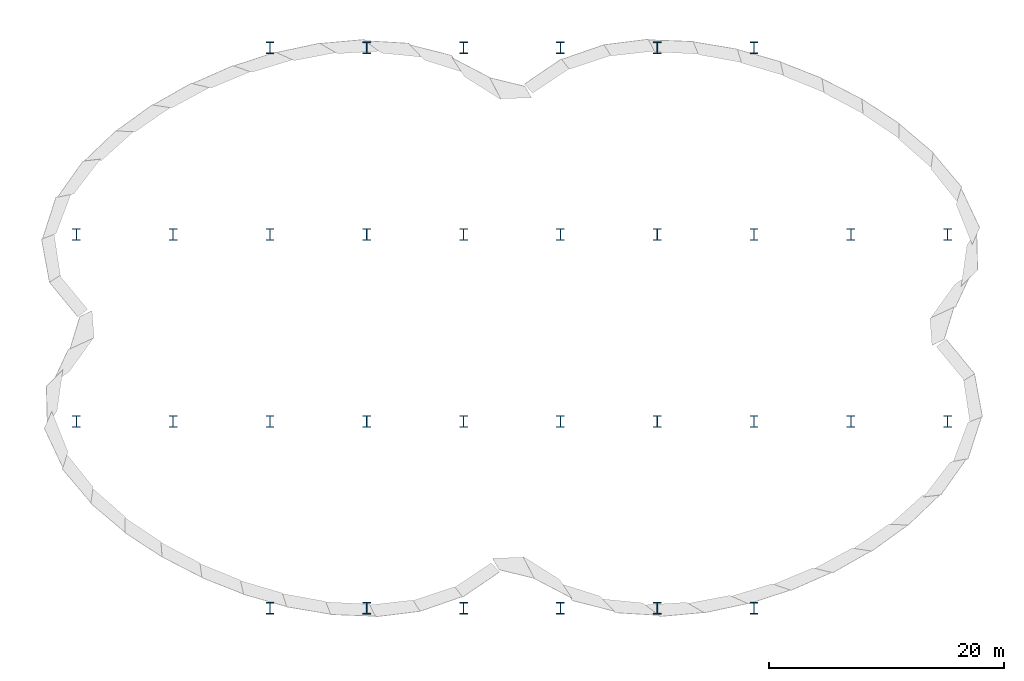
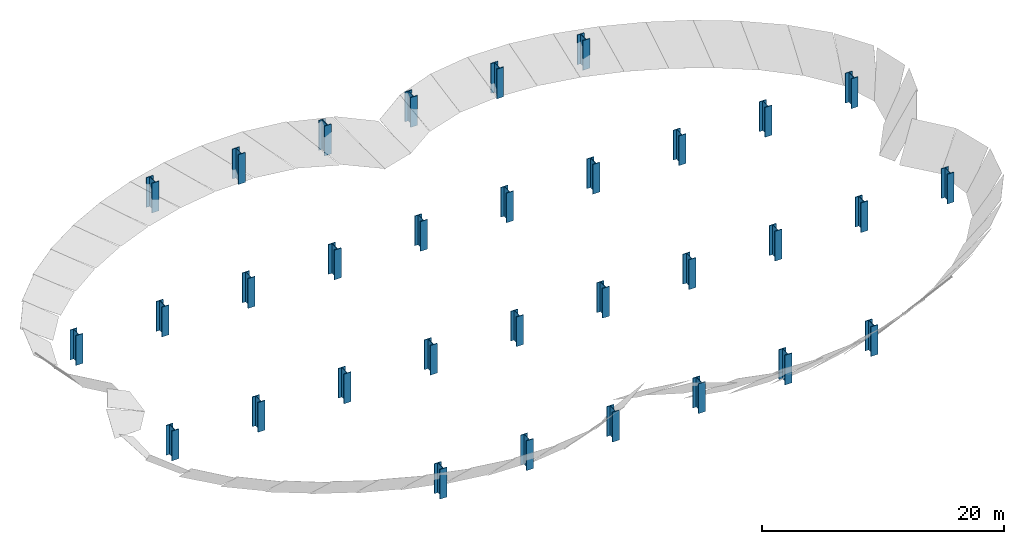
# One storey, part 1 of 2: 32 columns.
"""IFC2X3 building model written with IfcOpenShell, lengths in metres."""

from ifc_helpers import new_model, si_unit, direction, origin_with_axes, place, context, project, spatial, polyline, outline, extrude, source, transform, mapped, element, save


model = new_model("IFC2X3")

# Units and contexts
model_context = context("Model", 3, precision=1e-05, world=origin_with_axes(), true_north=direction((0.0, 1.0, 0.0)), identifier="Body")
ifc_project = project(units=[si_unit("LENGTHUNIT", "METRE"), si_unit("AREAUNIT", "SQUARE_METRE"), si_unit("VOLUMEUNIT", "CUBIC_METRE"), si_unit("PLANEANGLEUNIT", "RADIAN")], contexts=[model_context])

# Site, building, storey
site_placement = place(None, origin_with_axes())
site = spatial("IfcSite", under=ifc_project, at=site_placement, CompositionType="ELEMENT")
building_placement = place(None, origin_with_axes())
building = spatial("IfcBuilding", under=site, at=building_placement, Name="GH DEMO", CompositionType="ELEMENT")
storey_placement = place(None, origin_with_axes())
storey = spatial("IfcBuildingStorey", under=building, at=storey_placement, Name="Ground", CompositionType="ELEMENT")

# Columns
shared_shape_1 = source(origin_with_axes(), model_context, "Body", "SweptSolid", [
    extrude(outline(polyline([(0.025, -0.433333333333333), (0.025, 0.433333333333333), (0.333333333333333, 0.433333333333333), (0.333333333333333, 0.5), (-0.333333333333333, 0.5), (-0.333333333333333, 0.433333333333333), (-0.025, 0.433333333333333), (-0.025, -0.433333333333333), (-0.333333333333333, -0.433333333333333), (-0.333333333333333, -0.5), (0.333333333333333, -0.5), (0.333333333333333, -0.433333333333333), (0.025, -0.433333333333333)])), origin_with_axes(), (0.0, 0.0, 1.0), 3.0),
])
column_1_placement = place(None, origin_with_axes())
element("IfcColumn", 1, at=column_1_placement, inside=storey, context=model_context, shape_type="MappedRepresentation", body=[
    mapped(shared_shape_1, transform((4.1125, -7.9375, 0.0), x_axis=(1.0, 0.0, 0.0), y_axis=(0.0, 1.0, 0.0), z_axis=(0.0, 0.0, 1.0), scale=1.0)),
])
shared_shape_2 = source(origin_with_axes(), model_context, "Body", "SweptSolid", [
    extrude(outline(polyline([(0.025, -0.433333333333333), (0.025, 0.433333333333333), (0.333333333333333, 0.433333333333333), (0.333333333333333, 0.5), (-0.333333333333333, 0.5), (-0.333333333333333, 0.433333333333333), (-0.025, 0.433333333333333), (-0.025, -0.433333333333333), (-0.333333333333333, -0.433333333333333), (-0.333333333333333, -0.5), (0.333333333333333, -0.5), (0.333333333333333, -0.433333333333333), (0.025, -0.433333333333333)])), origin_with_axes(), (0.0, 0.0, 1.0), 3.0),
])
column_2_placement = place(None, origin_with_axes())
element("IfcColumn", 2, at=column_2_placement, inside=storey, context=model_context, shape_type="MappedRepresentation", body=[
    mapped(shared_shape_2, transform((12.3375, -7.9375, 0.0), x_axis=(1.0, 0.0, 0.0), y_axis=(0.0, 1.0, 0.0), z_axis=(0.0, 0.0, 1.0), scale=1.0)),
])
shared_shape_3 = source(origin_with_axes(), model_context, "Body", "SweptSolid", [
    extrude(outline(polyline([(0.025, -0.433333333333333), (0.025, 0.433333333333333), (0.333333333333333, 0.433333333333333), (0.333333333333333, 0.5), (-0.333333333333333, 0.5), (-0.333333333333333, 0.433333333333333), (-0.025, 0.433333333333333), (-0.025, -0.433333333333333), (-0.333333333333333, -0.433333333333333), (-0.333333333333333, -0.5), (0.333333333333333, -0.5), (0.333333333333333, -0.433333333333333), (0.025, -0.433333333333333)])), origin_with_axes(), (0.0, 0.0, 1.0), 3.0),
])
column_3_placement = place(None, origin_with_axes())
element("IfcColumn", 3, at=column_3_placement, inside=storey, context=model_context, shape_type="MappedRepresentation", body=[
    mapped(shared_shape_3, transform((20.5625, -7.9375, 0.0), x_axis=(1.0, 0.0, 0.0), y_axis=(0.0, 1.0, 0.0), z_axis=(0.0, 0.0, 1.0), scale=1.0)),
])
shared_shape_4 = source(origin_with_axes(), model_context, "Body", "SweptSolid", [
    extrude(outline(polyline([(0.025, -0.433333333333333), (0.025, 0.433333333333333), (0.333333333333333, 0.433333333333333), (0.333333333333333, 0.5), (-0.333333333333333, 0.5), (-0.333333333333333, 0.433333333333333), (-0.025, 0.433333333333333), (-0.025, -0.433333333333333), (-0.333333333333333, -0.433333333333333), (-0.333333333333333, -0.5), (0.333333333333333, -0.5), (0.333333333333333, -0.433333333333333), (0.025, -0.433333333333333)])), origin_with_axes(), (0.0, 0.0, 1.0), 3.0),
])
column_4_placement = place(None, origin_with_axes())
element("IfcColumn", 4, at=column_4_placement, inside=storey, context=model_context, shape_type="MappedRepresentation", body=[
    mapped(shared_shape_4, transform((28.7875, -7.9375, 0.0), x_axis=(1.0, 0.0, 0.0), y_axis=(0.0, 1.0, 0.0), z_axis=(0.0, 0.0, 1.0), scale=1.0)),
])
shared_shape_5 = source(origin_with_axes(), model_context, "Body", "SweptSolid", [
    extrude(outline(polyline([(0.025, -0.433333333333333), (0.025, 0.433333333333333), (0.333333333333333, 0.433333333333333), (0.333333333333333, 0.5), (-0.333333333333333, 0.5), (-0.333333333333333, 0.433333333333333), (-0.025, 0.433333333333333), (-0.025, -0.433333333333333), (-0.333333333333333, -0.433333333333333), (-0.333333333333333, -0.5), (0.333333333333333, -0.5), (0.333333333333333, -0.433333333333333), (0.025, -0.433333333333333)])), origin_with_axes(), (0.0, 0.0, 1.0), 3.0),
])
column_5_placement = place(None, origin_with_axes())
element("IfcColumn", 5, at=column_5_placement, inside=storey, context=model_context, shape_type="MappedRepresentation", body=[
    mapped(shared_shape_5, transform((37.0125, -7.9375, 0.0), x_axis=(1.0, 0.0, 0.0), y_axis=(0.0, 1.0, 0.0), z_axis=(0.0, 0.0, 1.0), scale=1.0)),
])
shared_shape_6 = source(origin_with_axes(), model_context, "Body", "SweptSolid", [
    extrude(outline(polyline([(0.025, -0.433333333333333), (0.025, 0.433333333333333), (0.333333333333333, 0.433333333333333), (0.333333333333333, 0.5), (-0.333333333333333, 0.5), (-0.333333333333333, 0.433333333333333), (-0.025, 0.433333333333333), (-0.025, -0.433333333333333), (-0.333333333333333, -0.433333333333333), (-0.333333333333333, -0.5), (0.333333333333333, -0.5), (0.333333333333333, -0.433333333333333), (0.025, -0.433333333333333)])), origin_with_axes(), (0.0, 0.0, 1.0), 3.0),
])
column_6_placement = place(None, origin_with_axes())
element("IfcColumn", 6, at=column_6_placement, inside=storey, context=model_context, shape_type="MappedRepresentation", body=[
    mapped(shared_shape_6, transform((-4.1125, -7.9375, 0.0), x_axis=(1.0, 0.0, 0.0), y_axis=(0.0, 1.0, 0.0), z_axis=(0.0, 0.0, 1.0), scale=1.0)),
])
shared_shape_7 = source(origin_with_axes(), model_context, "Body", "SweptSolid", [
    extrude(outline(polyline([(0.025, -0.433333333333333), (0.025, 0.433333333333333), (0.333333333333333, 0.433333333333333), (0.333333333333333, 0.5), (-0.333333333333333, 0.5), (-0.333333333333333, 0.433333333333333), (-0.025, 0.433333333333333), (-0.025, -0.433333333333333), (-0.333333333333333, -0.433333333333333), (-0.333333333333333, -0.5), (0.333333333333333, -0.5), (0.333333333333333, -0.433333333333333), (0.025, -0.433333333333333)])), origin_with_axes(), (0.0, 0.0, 1.0), 3.0),
])
column_7_placement = place(None, origin_with_axes())
element("IfcColumn", 7, at=column_7_placement, inside=storey, context=model_context, shape_type="MappedRepresentation", body=[
    mapped(shared_shape_7, transform((-12.3375, -7.9375, 0.0), x_axis=(1.0, 0.0, 0.0), y_axis=(0.0, 1.0, 0.0), z_axis=(0.0, 0.0, 1.0), scale=1.0)),
])
shared_shape_8 = source(origin_with_axes(), model_context, "Body", "SweptSolid", [
    extrude(outline(polyline([(0.025, -0.433333333333333), (0.025, 0.433333333333333), (0.333333333333333, 0.433333333333333), (0.333333333333333, 0.5), (-0.333333333333333, 0.5), (-0.333333333333333, 0.433333333333333), (-0.025, 0.433333333333333), (-0.025, -0.433333333333333), (-0.333333333333333, -0.433333333333333), (-0.333333333333333, -0.5), (0.333333333333333, -0.5), (0.333333333333333, -0.433333333333333), (0.025, -0.433333333333333)])), origin_with_axes(), (0.0, 0.0, 1.0), 3.0),
])
column_8_placement = place(None, origin_with_axes())
element("IfcColumn", 8, at=column_8_placement, inside=storey, context=model_context, shape_type="MappedRepresentation", body=[
    mapped(shared_shape_8, transform((-20.5625, -7.9375, 0.0), x_axis=(1.0, 0.0, 0.0), y_axis=(0.0, 1.0, 0.0), z_axis=(0.0, 0.0, 1.0), scale=1.0)),
])
shared_shape_9 = source(origin_with_axes(), model_context, "Body", "SweptSolid", [
    extrude(outline(polyline([(0.025, -0.433333333333333), (0.025, 0.433333333333333), (0.333333333333333, 0.433333333333333), (0.333333333333333, 0.5), (-0.333333333333333, 0.5), (-0.333333333333333, 0.433333333333333), (-0.025, 0.433333333333333), (-0.025, -0.433333333333333), (-0.333333333333333, -0.433333333333333), (-0.333333333333333, -0.5), (0.333333333333333, -0.5), (0.333333333333333, -0.433333333333333), (0.025, -0.433333333333333)])), origin_with_axes(), (0.0, 0.0, 1.0), 3.0),
])
column_9_placement = place(None, origin_with_axes())
element("IfcColumn", 9, at=column_9_placement, inside=storey, context=model_context, shape_type="MappedRepresentation", body=[
    mapped(shared_shape_9, transform((-28.7875, -7.9375, 0.0), x_axis=(1.0, 0.0, 0.0), y_axis=(0.0, 1.0, 0.0), z_axis=(0.0, 0.0, 1.0), scale=1.0)),
])
shared_shape_10 = source(origin_with_axes(), model_context, "Body", "SweptSolid", [
    extrude(outline(polyline([(0.025, -0.433333333333333), (0.025, 0.433333333333333), (0.333333333333333, 0.433333333333333), (0.333333333333333, 0.5), (-0.333333333333333, 0.5), (-0.333333333333333, 0.433333333333333), (-0.025, 0.433333333333333), (-0.025, -0.433333333333333), (-0.333333333333333, -0.433333333333333), (-0.333333333333333, -0.5), (0.333333333333333, -0.5), (0.333333333333333, -0.433333333333333), (0.025, -0.433333333333333)])), origin_with_axes(), (0.0, 0.0, 1.0), 3.0),
])
column_10_placement = place(None, origin_with_axes())
element("IfcColumn", 10, at=column_10_placement, inside=storey, context=model_context, shape_type="MappedRepresentation", body=[
    mapped(shared_shape_10, transform((-37.0125, -7.9375, 0.0), x_axis=(1.0, 0.0, 0.0), y_axis=(0.0, 1.0, 0.0), z_axis=(0.0, 0.0, 1.0), scale=1.0)),
])
shared_shape_11 = source(origin_with_axes(), model_context, "Body", "SweptSolid", [
    extrude(outline(polyline([(0.025, -0.433333333333333), (0.025, 0.433333333333333), (0.333333333333333, 0.433333333333333), (0.333333333333333, 0.5), (-0.333333333333333, 0.5), (-0.333333333333333, 0.433333333333333), (-0.025, 0.433333333333333), (-0.025, -0.433333333333333), (-0.333333333333333, -0.433333333333333), (-0.333333333333333, -0.5), (0.333333333333333, -0.5), (0.333333333333333, -0.433333333333333), (0.025, -0.433333333333333)])), origin_with_axes(), (0.0, 0.0, 1.0), 3.0),
])
column_11_placement = place(None, origin_with_axes())
element("IfcColumn", 11, at=column_11_placement, inside=storey, context=model_context, shape_type="MappedRepresentation", body=[
    mapped(shared_shape_11, transform((4.1125, -23.8125, 0.0), x_axis=(1.0, 0.0, 0.0), y_axis=(0.0, 1.0, 0.0), z_axis=(0.0, 0.0, 1.0), scale=1.0)),
])
shared_shape_12 = source(origin_with_axes(), model_context, "Body", "SweptSolid", [
    extrude(outline(polyline([(0.025, -0.433333333333333), (0.025, 0.433333333333333), (0.333333333333333, 0.433333333333333), (0.333333333333333, 0.5), (-0.333333333333333, 0.5), (-0.333333333333333, 0.433333333333333), (-0.025, 0.433333333333333), (-0.025, -0.433333333333333), (-0.333333333333333, -0.433333333333333), (-0.333333333333333, -0.5), (0.333333333333333, -0.5), (0.333333333333333, -0.433333333333333), (0.025, -0.433333333333333)])), origin_with_axes(), (0.0, 0.0, 1.0), 3.0),
])
column_12_placement = place(None, origin_with_axes())
element("IfcColumn", 12, at=column_12_placement, inside=storey, context=model_context, shape_type="MappedRepresentation", body=[
    mapped(shared_shape_12, transform((12.3375, -23.8125, 0.0), x_axis=(1.0, 0.0, 0.0), y_axis=(0.0, 1.0, 0.0), z_axis=(0.0, 0.0, 1.0), scale=1.0)),
])
shared_shape_13 = source(origin_with_axes(), model_context, "Body", "SweptSolid", [
    extrude(outline(polyline([(0.025, -0.433333333333333), (0.025, 0.433333333333333), (0.333333333333333, 0.433333333333333), (0.333333333333333, 0.5), (-0.333333333333333, 0.5), (-0.333333333333333, 0.433333333333333), (-0.025, 0.433333333333333), (-0.025, -0.433333333333333), (-0.333333333333333, -0.433333333333333), (-0.333333333333333, -0.5), (0.333333333333333, -0.5), (0.333333333333333, -0.433333333333333), (0.025, -0.433333333333333)])), origin_with_axes(), (0.0, 0.0, 1.0), 3.0),
])
column_13_placement = place(None, origin_with_axes())
element("IfcColumn", 13, at=column_13_placement, inside=storey, context=model_context, shape_type="MappedRepresentation", body=[
    mapped(shared_shape_13, transform((20.5625, -23.8125, 0.0), x_axis=(1.0, 0.0, 0.0), y_axis=(0.0, 1.0, 0.0), z_axis=(0.0, 0.0, 1.0), scale=1.0)),
])
shared_shape_14 = source(origin_with_axes(), model_context, "Body", "SweptSolid", [
    extrude(outline(polyline([(0.025, -0.433333333333333), (0.025, 0.433333333333333), (0.333333333333333, 0.433333333333333), (0.333333333333333, 0.5), (-0.333333333333333, 0.5), (-0.333333333333333, 0.433333333333333), (-0.025, 0.433333333333333), (-0.025, -0.433333333333333), (-0.333333333333333, -0.433333333333333), (-0.333333333333333, -0.5), (0.333333333333333, -0.5), (0.333333333333333, -0.433333333333333), (0.025, -0.433333333333333)])), origin_with_axes(), (0.0, 0.0, 1.0), 3.0),
])
column_14_placement = place(None, origin_with_axes())
element("IfcColumn", 14, at=column_14_placement, inside=storey, context=model_context, shape_type="MappedRepresentation", body=[
    mapped(shared_shape_14, transform((-4.1125, -23.8125, 0.0), x_axis=(1.0, 0.0, 0.0), y_axis=(0.0, 1.0, 0.0), z_axis=(0.0, 0.0, 1.0), scale=1.0)),
])
shared_shape_15 = source(origin_with_axes(), model_context, "Body", "SweptSolid", [
    extrude(outline(polyline([(0.025, -0.433333333333333), (0.025, 0.433333333333333), (0.333333333333333, 0.433333333333333), (0.333333333333333, 0.5), (-0.333333333333333, 0.5), (-0.333333333333333, 0.433333333333333), (-0.025, 0.433333333333333), (-0.025, -0.433333333333333), (-0.333333333333333, -0.433333333333333), (-0.333333333333333, -0.5), (0.333333333333333, -0.5), (0.333333333333333, -0.433333333333333), (0.025, -0.433333333333333)])), origin_with_axes(), (0.0, 0.0, 1.0), 3.0),
])
column_15_placement = place(None, origin_with_axes())
element("IfcColumn", 15, at=column_15_placement, inside=storey, context=model_context, shape_type="MappedRepresentation", body=[
    mapped(shared_shape_15, transform((-12.3375, -23.8125, 0.0), x_axis=(1.0, 0.0, 0.0), y_axis=(0.0, 1.0, 0.0), z_axis=(0.0, 0.0, 1.0), scale=1.0)),
])
shared_shape_16 = source(origin_with_axes(), model_context, "Body", "SweptSolid", [
    extrude(outline(polyline([(0.025, -0.433333333333333), (0.025, 0.433333333333333), (0.333333333333333, 0.433333333333333), (0.333333333333333, 0.5), (-0.333333333333333, 0.5), (-0.333333333333333, 0.433333333333333), (-0.025, 0.433333333333333), (-0.025, -0.433333333333333), (-0.333333333333333, -0.433333333333333), (-0.333333333333333, -0.5), (0.333333333333333, -0.5), (0.333333333333333, -0.433333333333333), (0.025, -0.433333333333333)])), origin_with_axes(), (0.0, 0.0, 1.0), 3.0),
])
column_16_placement = place(None, origin_with_axes())
element("IfcColumn", 16, at=column_16_placement, inside=storey, context=model_context, shape_type="MappedRepresentation", body=[
    mapped(shared_shape_16, transform((-20.5625, -23.8125, 0.0), x_axis=(1.0, 0.0, 0.0), y_axis=(0.0, 1.0, 0.0), z_axis=(0.0, 0.0, 1.0), scale=1.0)),
])
shared_shape_17 = source(origin_with_axes(), model_context, "Body", "SweptSolid", [
    extrude(outline(polyline([(0.025, -0.433333333333333), (0.025, 0.433333333333333), (0.333333333333333, 0.433333333333333), (0.333333333333333, 0.5), (-0.333333333333333, 0.5), (-0.333333333333333, 0.433333333333333), (-0.025, 0.433333333333333), (-0.025, -0.433333333333333), (-0.333333333333333, -0.433333333333333), (-0.333333333333333, -0.5), (0.333333333333333, -0.5), (0.333333333333333, -0.433333333333333), (0.025, -0.433333333333333)])), origin_with_axes(), (0.0, 0.0, 1.0), 3.0),
])
column_17_placement = place(None, origin_with_axes())
element("IfcColumn", 17, at=column_17_placement, inside=storey, context=model_context, shape_type="MappedRepresentation", body=[
    mapped(shared_shape_17, transform((4.1125, 7.9375, 0.0), x_axis=(1.0, 0.0, 0.0), y_axis=(0.0, 1.0, 0.0), z_axis=(0.0, 0.0, 1.0), scale=1.0)),
])
shared_shape_18 = source(origin_with_axes(), model_context, "Body", "SweptSolid", [
    extrude(outline(polyline([(0.025, -0.433333333333333), (0.025, 0.433333333333333), (0.333333333333333, 0.433333333333333), (0.333333333333333, 0.5), (-0.333333333333333, 0.5), (-0.333333333333333, 0.433333333333333), (-0.025, 0.433333333333333), (-0.025, -0.433333333333333), (-0.333333333333333, -0.433333333333333), (-0.333333333333333, -0.5), (0.333333333333333, -0.5), (0.333333333333333, -0.433333333333333), (0.025, -0.433333333333333)])), origin_with_axes(), (0.0, 0.0, 1.0), 3.0),
])
column_18_placement = place(None, origin_with_axes())
element("IfcColumn", 18, at=column_18_placement, inside=storey, context=model_context, shape_type="MappedRepresentation", body=[
    mapped(shared_shape_18, transform((12.3375, 7.9375, 0.0), x_axis=(1.0, 0.0, 0.0), y_axis=(0.0, 1.0, 0.0), z_axis=(0.0, 0.0, 1.0), scale=1.0)),
])
shared_shape_19 = source(origin_with_axes(), model_context, "Body", "SweptSolid", [
    extrude(outline(polyline([(0.025, -0.433333333333333), (0.025, 0.433333333333333), (0.333333333333333, 0.433333333333333), (0.333333333333333, 0.5), (-0.333333333333333, 0.5), (-0.333333333333333, 0.433333333333333), (-0.025, 0.433333333333333), (-0.025, -0.433333333333333), (-0.333333333333333, -0.433333333333333), (-0.333333333333333, -0.5), (0.333333333333333, -0.5), (0.333333333333333, -0.433333333333333), (0.025, -0.433333333333333)])), origin_with_axes(), (0.0, 0.0, 1.0), 3.0),
])
column_19_placement = place(None, origin_with_axes())
element("IfcColumn", 19, at=column_19_placement, inside=storey, context=model_context, shape_type="MappedRepresentation", body=[
    mapped(shared_shape_19, transform((20.5625, 7.9375, 0.0), x_axis=(1.0, 0.0, 0.0), y_axis=(0.0, 1.0, 0.0), z_axis=(0.0, 0.0, 1.0), scale=1.0)),
])
shared_shape_20 = source(origin_with_axes(), model_context, "Body", "SweptSolid", [
    extrude(outline(polyline([(0.025, -0.433333333333333), (0.025, 0.433333333333333), (0.333333333333333, 0.433333333333333), (0.333333333333333, 0.5), (-0.333333333333333, 0.5), (-0.333333333333333, 0.433333333333333), (-0.025, 0.433333333333333), (-0.025, -0.433333333333333), (-0.333333333333333, -0.433333333333333), (-0.333333333333333, -0.5), (0.333333333333333, -0.5), (0.333333333333333, -0.433333333333333), (0.025, -0.433333333333333)])), origin_with_axes(), (0.0, 0.0, 1.0), 3.0),
])
column_20_placement = place(None, origin_with_axes())
element("IfcColumn", 20, at=column_20_placement, inside=storey, context=model_context, shape_type="MappedRepresentation", body=[
    mapped(shared_shape_20, transform((28.7875, 7.9375, 0.0), x_axis=(1.0, 0.0, 0.0), y_axis=(0.0, 1.0, 0.0), z_axis=(0.0, 0.0, 1.0), scale=1.0)),
])
shared_shape_21 = source(origin_with_axes(), model_context, "Body", "SweptSolid", [
    extrude(outline(polyline([(0.025, -0.433333333333333), (0.025, 0.433333333333333), (0.333333333333333, 0.433333333333333), (0.333333333333333, 0.5), (-0.333333333333333, 0.5), (-0.333333333333333, 0.433333333333333), (-0.025, 0.433333333333333), (-0.025, -0.433333333333333), (-0.333333333333333, -0.433333333333333), (-0.333333333333333, -0.5), (0.333333333333333, -0.5), (0.333333333333333, -0.433333333333333), (0.025, -0.433333333333333)])), origin_with_axes(), (0.0, 0.0, 1.0), 3.0),
])
column_21_placement = place(None, origin_with_axes())
element("IfcColumn", 21, at=column_21_placement, inside=storey, context=model_context, shape_type="MappedRepresentation", body=[
    mapped(shared_shape_21, transform((37.0125, 7.9375, 0.0), x_axis=(1.0, 0.0, 0.0), y_axis=(0.0, 1.0, 0.0), z_axis=(0.0, 0.0, 1.0), scale=1.0)),
])
shared_shape_22 = source(origin_with_axes(), model_context, "Body", "SweptSolid", [
    extrude(outline(polyline([(0.025, -0.433333333333333), (0.025, 0.433333333333333), (0.333333333333333, 0.433333333333333), (0.333333333333333, 0.5), (-0.333333333333333, 0.5), (-0.333333333333333, 0.433333333333333), (-0.025, 0.433333333333333), (-0.025, -0.433333333333333), (-0.333333333333333, -0.433333333333333), (-0.333333333333333, -0.5), (0.333333333333333, -0.5), (0.333333333333333, -0.433333333333333), (0.025, -0.433333333333333)])), origin_with_axes(), (0.0, 0.0, 1.0), 3.0),
])
column_22_placement = place(None, origin_with_axes())
element("IfcColumn", 22, at=column_22_placement, inside=storey, context=model_context, shape_type="MappedRepresentation", body=[
    mapped(shared_shape_22, transform((-4.1125, 7.9375, 0.0), x_axis=(1.0, 0.0, 0.0), y_axis=(0.0, 1.0, 0.0), z_axis=(0.0, 0.0, 1.0), scale=1.0)),
])
shared_shape_23 = source(origin_with_axes(), model_context, "Body", "SweptSolid", [
    extrude(outline(polyline([(0.025, -0.433333333333333), (0.025, 0.433333333333333), (0.333333333333333, 0.433333333333333), (0.333333333333333, 0.5), (-0.333333333333333, 0.5), (-0.333333333333333, 0.433333333333333), (-0.025, 0.433333333333333), (-0.025, -0.433333333333333), (-0.333333333333333, -0.433333333333333), (-0.333333333333333, -0.5), (0.333333333333333, -0.5), (0.333333333333333, -0.433333333333333), (0.025, -0.433333333333333)])), origin_with_axes(), (0.0, 0.0, 1.0), 3.0),
])
column_23_placement = place(None, origin_with_axes())
element("IfcColumn", 23, at=column_23_placement, inside=storey, context=model_context, shape_type="MappedRepresentation", body=[
    mapped(shared_shape_23, transform((-12.3375, 7.9375, 0.0), x_axis=(1.0, 0.0, 0.0), y_axis=(0.0, 1.0, 0.0), z_axis=(0.0, 0.0, 1.0), scale=1.0)),
])
shared_shape_24 = source(origin_with_axes(), model_context, "Body", "SweptSolid", [
    extrude(outline(polyline([(0.025, -0.433333333333333), (0.025, 0.433333333333333), (0.333333333333333, 0.433333333333333), (0.333333333333333, 0.5), (-0.333333333333333, 0.5), (-0.333333333333333, 0.433333333333333), (-0.025, 0.433333333333333), (-0.025, -0.433333333333333), (-0.333333333333333, -0.433333333333333), (-0.333333333333333, -0.5), (0.333333333333333, -0.5), (0.333333333333333, -0.433333333333333), (0.025, -0.433333333333333)])), origin_with_axes(), (0.0, 0.0, 1.0), 3.0),
])
column_24_placement = place(None, origin_with_axes())
element("IfcColumn", 24, at=column_24_placement, inside=storey, context=model_context, shape_type="MappedRepresentation", body=[
    mapped(shared_shape_24, transform((-20.5625, 7.9375, 0.0), x_axis=(1.0, 0.0, 0.0), y_axis=(0.0, 1.0, 0.0), z_axis=(0.0, 0.0, 1.0), scale=1.0)),
])
shared_shape_25 = source(origin_with_axes(), model_context, "Body", "SweptSolid", [
    extrude(outline(polyline([(0.025, -0.433333333333333), (0.025, 0.433333333333333), (0.333333333333333, 0.433333333333333), (0.333333333333333, 0.5), (-0.333333333333333, 0.5), (-0.333333333333333, 0.433333333333333), (-0.025, 0.433333333333333), (-0.025, -0.433333333333333), (-0.333333333333333, -0.433333333333333), (-0.333333333333333, -0.5), (0.333333333333333, -0.5), (0.333333333333333, -0.433333333333333), (0.025, -0.433333333333333)])), origin_with_axes(), (0.0, 0.0, 1.0), 3.0),
])
column_25_placement = place(None, origin_with_axes())
element("IfcColumn", 25, at=column_25_placement, inside=storey, context=model_context, shape_type="MappedRepresentation", body=[
    mapped(shared_shape_25, transform((-28.7875, 7.9375, 0.0), x_axis=(1.0, 0.0, 0.0), y_axis=(0.0, 1.0, 0.0), z_axis=(0.0, 0.0, 1.0), scale=1.0)),
])
shared_shape_26 = source(origin_with_axes(), model_context, "Body", "SweptSolid", [
    extrude(outline(polyline([(0.025, -0.433333333333333), (0.025, 0.433333333333333), (0.333333333333333, 0.433333333333333), (0.333333333333333, 0.5), (-0.333333333333333, 0.5), (-0.333333333333333, 0.433333333333333), (-0.025, 0.433333333333333), (-0.025, -0.433333333333333), (-0.333333333333333, -0.433333333333333), (-0.333333333333333, -0.5), (0.333333333333333, -0.5), (0.333333333333333, -0.433333333333333), (0.025, -0.433333333333333)])), origin_with_axes(), (0.0, 0.0, 1.0), 3.0),
])
column_26_placement = place(None, origin_with_axes())
element("IfcColumn", 26, at=column_26_placement, inside=storey, context=model_context, shape_type="MappedRepresentation", body=[
    mapped(shared_shape_26, transform((-37.0125, 7.9375, 0.0), x_axis=(1.0, 0.0, 0.0), y_axis=(0.0, 1.0, 0.0), z_axis=(0.0, 0.0, 1.0), scale=1.0)),
])
shared_shape_27 = source(origin_with_axes(), model_context, "Body", "SweptSolid", [
    extrude(outline(polyline([(0.025, -0.433333333333333), (0.025, 0.433333333333333), (0.333333333333333, 0.433333333333333), (0.333333333333333, 0.5), (-0.333333333333333, 0.5), (-0.333333333333333, 0.433333333333333), (-0.025, 0.433333333333333), (-0.025, -0.433333333333333), (-0.333333333333333, -0.433333333333333), (-0.333333333333333, -0.5), (0.333333333333333, -0.5), (0.333333333333333, -0.433333333333333), (0.025, -0.433333333333333)])), origin_with_axes(), (0.0, 0.0, 1.0), 3.0),
])
column_27_placement = place(None, origin_with_axes())
element("IfcColumn", 27, at=column_27_placement, inside=storey, context=model_context, shape_type="MappedRepresentation", body=[
    mapped(shared_shape_27, transform((4.1125, 23.8125, 0.0), x_axis=(1.0, 0.0, 0.0), y_axis=(0.0, 1.0, 0.0), z_axis=(0.0, 0.0, 1.0), scale=1.0)),
])
shared_shape_28 = source(origin_with_axes(), model_context, "Body", "SweptSolid", [
    extrude(outline(polyline([(0.025, -0.433333333333333), (0.025, 0.433333333333333), (0.333333333333333, 0.433333333333333), (0.333333333333333, 0.5), (-0.333333333333333, 0.5), (-0.333333333333333, 0.433333333333333), (-0.025, 0.433333333333333), (-0.025, -0.433333333333333), (-0.333333333333333, -0.433333333333333), (-0.333333333333333, -0.5), (0.333333333333333, -0.5), (0.333333333333333, -0.433333333333333), (0.025, -0.433333333333333)])), origin_with_axes(), (0.0, 0.0, 1.0), 3.0),
])
column_28_placement = place(None, origin_with_axes())
element("IfcColumn", 28, at=column_28_placement, inside=storey, context=model_context, shape_type="MappedRepresentation", body=[
    mapped(shared_shape_28, transform((12.3375, 23.8125, 0.0), x_axis=(1.0, 0.0, 0.0), y_axis=(0.0, 1.0, 0.0), z_axis=(0.0, 0.0, 1.0), scale=1.0)),
])
shared_shape_29 = source(origin_with_axes(), model_context, "Body", "SweptSolid", [
    extrude(outline(polyline([(0.025, -0.433333333333333), (0.025, 0.433333333333333), (0.333333333333333, 0.433333333333333), (0.333333333333333, 0.5), (-0.333333333333333, 0.5), (-0.333333333333333, 0.433333333333333), (-0.025, 0.433333333333333), (-0.025, -0.433333333333333), (-0.333333333333333, -0.433333333333333), (-0.333333333333333, -0.5), (0.333333333333333, -0.5), (0.333333333333333, -0.433333333333333), (0.025, -0.433333333333333)])), origin_with_axes(), (0.0, 0.0, 1.0), 3.0),
])
column_29_placement = place(None, origin_with_axes())
element("IfcColumn", 29, at=column_29_placement, inside=storey, context=model_context, shape_type="MappedRepresentation", body=[
    mapped(shared_shape_29, transform((20.5625, 23.8125, 0.0), x_axis=(1.0, 0.0, 0.0), y_axis=(0.0, 1.0, 0.0), z_axis=(0.0, 0.0, 1.0), scale=1.0)),
])
shared_shape_30 = source(origin_with_axes(), model_context, "Body", "SweptSolid", [
    extrude(outline(polyline([(0.025, -0.433333333333333), (0.025, 0.433333333333333), (0.333333333333333, 0.433333333333333), (0.333333333333333, 0.5), (-0.333333333333333, 0.5), (-0.333333333333333, 0.433333333333333), (-0.025, 0.433333333333333), (-0.025, -0.433333333333333), (-0.333333333333333, -0.433333333333333), (-0.333333333333333, -0.5), (0.333333333333333, -0.5), (0.333333333333333, -0.433333333333333), (0.025, -0.433333333333333)])), origin_with_axes(), (0.0, 0.0, 1.0), 3.0),
])
column_30_placement = place(None, origin_with_axes())
element("IfcColumn", 30, at=column_30_placement, inside=storey, context=model_context, shape_type="MappedRepresentation", body=[
    mapped(shared_shape_30, transform((-4.1125, 23.8125, 0.0), x_axis=(1.0, 0.0, 0.0), y_axis=(0.0, 1.0, 0.0), z_axis=(0.0, 0.0, 1.0), scale=1.0)),
])
shared_shape_31 = source(origin_with_axes(), model_context, "Body", "SweptSolid", [
    extrude(outline(polyline([(0.025, -0.433333333333333), (0.025, 0.433333333333333), (0.333333333333333, 0.433333333333333), (0.333333333333333, 0.5), (-0.333333333333333, 0.5), (-0.333333333333333, 0.433333333333333), (-0.025, 0.433333333333333), (-0.025, -0.433333333333333), (-0.333333333333333, -0.433333333333333), (-0.333333333333333, -0.5), (0.333333333333333, -0.5), (0.333333333333333, -0.433333333333333), (0.025, -0.433333333333333)])), origin_with_axes(), (0.0, 0.0, 1.0), 3.0),
])
column_31_placement = place(None, origin_with_axes())
element("IfcColumn", 31, at=column_31_placement, inside=storey, context=model_context, shape_type="MappedRepresentation", body=[
    mapped(shared_shape_31, transform((-12.3375, 23.8125, 0.0), x_axis=(1.0, 0.0, 0.0), y_axis=(0.0, 1.0, 0.0), z_axis=(0.0, 0.0, 1.0), scale=1.0)),
])
shared_shape_32 = source(origin_with_axes(), model_context, "Body", "SweptSolid", [
    extrude(outline(polyline([(0.025, -0.433333333333333), (0.025, 0.433333333333333), (0.333333333333333, 0.433333333333333), (0.333333333333333, 0.5), (-0.333333333333333, 0.5), (-0.333333333333333, 0.433333333333333), (-0.025, 0.433333333333333), (-0.025, -0.433333333333333), (-0.333333333333333, -0.433333333333333), (-0.333333333333333, -0.5), (0.333333333333333, -0.5), (0.333333333333333, -0.433333333333333), (0.025, -0.433333333333333)])), origin_with_axes(), (0.0, 0.0, 1.0), 3.0),
])
column_32_placement = place(None, origin_with_axes())
element("IfcColumn", 32, at=column_32_placement, inside=storey, context=model_context, shape_type="MappedRepresentation", body=[
    mapped(shared_shape_32, transform((-20.5625, 23.8125, 0.0), x_axis=(1.0, 0.0, 0.0), y_axis=(0.0, 1.0, 0.0), z_axis=(0.0, 0.0, 1.0), scale=1.0)),
])

save(model, "model.ifc")
